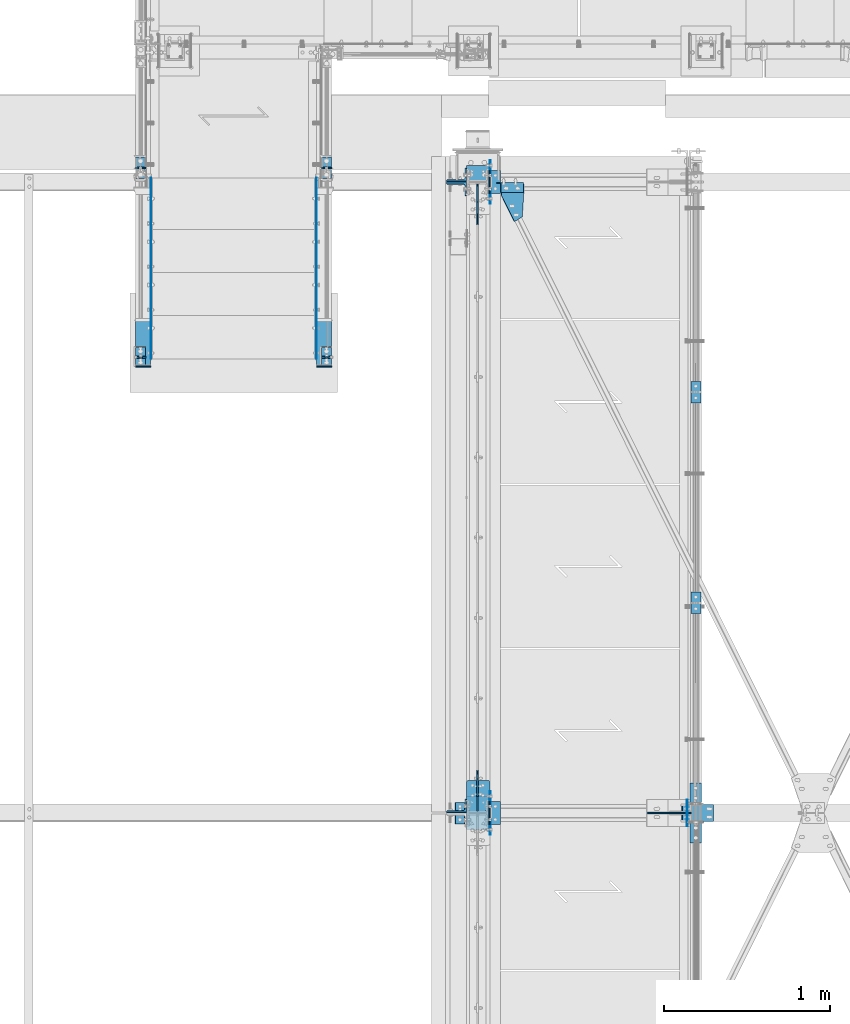
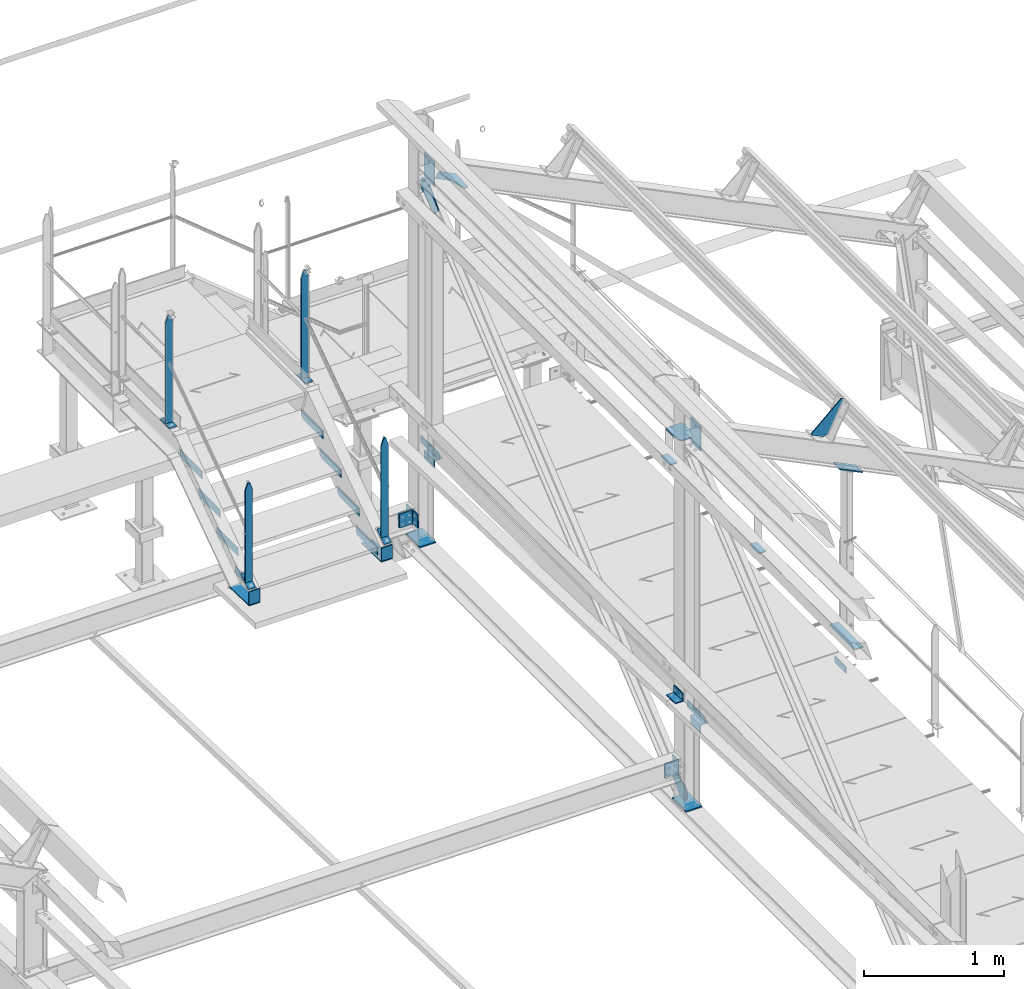
# One storey, part 110 of 496: 36 beams, 7 members, 25 elements without a shape of their own.
"""IFC2X3 building model written with IfcOpenShell, lengths in millimetres."""

from ifc_helpers import new_model, si_unit, frame, frame_2d, origin_with_axes, origin_2d_with_axis, place, context, subcontext, project, spatial, polyline, circle_curve, parameter, trimmed, segment, composite_curve, rectangle, l_section, outline, extrude, clip, halfspace, material, type_object, element, aggregate, save


model = new_model("IFC2X3")

# Units and contexts
model_context = context("Model", 3, precision=1e-05, world=origin_with_axes())
body_context = subcontext(model_context, "Body", "Model", "MODEL_VIEW")
ifc_project = project(units=[si_unit("LENGTHUNIT", "METRE", prefix="MILLI"), si_unit("AREAUNIT", "SQUARE_METRE"), si_unit("VOLUMEUNIT", "CUBIC_METRE"), si_unit("MASSUNIT", "GRAM", prefix="KILO"), si_unit("TIMEUNIT", "SECOND"), si_unit("PLANEANGLEUNIT", "RADIAN"), si_unit("SOLIDANGLEUNIT", "STERADIAN"), si_unit("THERMODYNAMICTEMPERATUREUNIT", "DEGREE_CELSIUS"), si_unit("LUMINOUSINTENSITYUNIT", "LUMEN")], contexts=[model_context])

# Site, building, storey
site_placement = place(None, origin_with_axes())
site = spatial("IfcSite", under=ifc_project, at=site_placement, CompositionType="ELEMENT")
building_placement = place(site_placement, origin_with_axes())
building = spatial("IfcBuilding", under=site, at=building_placement, Name="Undefined", CompositionType="ELEMENT")
storey_placement = place(building_placement, origin_with_axes())
storey = spatial("IfcBuildingStorey", under=building, at=storey_placement, Name="Undefined", CompositionType="ELEMENT", Elevation=0.0)

# Assembly, beams
assembly_1_placement = place(storey_placement, origin_with_axes())
assembly_1 = element("IfcElementAssembly", 1, at=assembly_1_placement, inside=storey, Name="MAIN COURANTE", AssemblyPlace="NOTDEFINED", PredefinedType="NOTDEFINED")
ifc_material = material(Name="Undefined/S235-E24")
beam_type_1 = type_object("IfcBeamType", PredefinedType="NOTDEFINED")
beam_1_placement = place(assembly_1_placement, frame((33369.9936634988, 15350.0038033311, 8915.0), z_axis=(1.0, 0.0, 0.0), x_axis=(0.0, -1.0, 0.0)))
beam_1 = element("IfcBeam", 2, at=beam_1_placement, type_object=beam_type_1, material=ifc_material, context=body_context, shape_type="SweptSolid", body=[
    extrude(rectangle(XDim=10.0, YDim=60.0, at=origin_2d_with_axis()), frame((130.0, 0.0, 0.0), z_axis=(-1.0, 0.0, 0.0), x_axis=(0.0, -1.0, 0.0)), (0.0, 0.0, 1.0), 130.0),
])
beam_2_placement = place(assembly_1_placement, frame((33369.9937887991, 15285.0038033311, 9857.59999847), z_axis=(0.999999999998558, -1.69800000185205e-06, 0.0), x_axis=(0.0, 0.0, -1.0)))
beam_2 = element("IfcBeam", 3, at=beam_2_placement, type_object=beam_type_1, material=ifc_material, Name="MONTANT", context=body_context, shape_type="Clipping", body=[
    clip(clip(extrude(rectangle(XDim=10.0, YDim=60.0, at=origin_2d_with_axis()), frame((937.599998469999, 0.0, 0.0), z_axis=(-1.0, 0.0, 0.0), x_axis=(0.0, -1.0, 0.0)), (0.0, 0.0, 1.0), 937.6), halfspace(frame((-119.999937359999, 4.99999999999818, -30.0), z_axis=(-0.316227766016843, 1.98085072621335e-06, 0.948683298048444), x_axis=(0.948683298050514, 0.0, 0.316227766016838)), False)), halfspace(frame((60.0, 5.0, -30.0), z_axis=(-0.316227469016822, -1.98084886580522e-06, -0.948683397048399), x_axis=(-0.948683298050514, 0.0, 0.316227766016838)), False)),
])

assembly_2_placement = place(storey_placement, origin_with_axes())
assembly_2 = element("IfcElementAssembly", 4, at=assembly_2_placement, inside=storey, Name="MAIN COURANTE", AssemblyPlace="NOTDEFINED", PredefinedType="NOTDEFINED")
beam_3_placement = place(assembly_2_placement, frame((32249.9863365012, 15350.0038033311, 8915.0), z_axis=(-1.0, 0.0, 0.0), x_axis=(0.0, -1.0, 0.0)))
beam_3 = element("IfcBeam", 5, at=beam_3_placement, type_object=beam_type_1, material=ifc_material, context=body_context, shape_type="SweptSolid", body=[
    extrude(rectangle(XDim=10.0, YDim=60.0, at=origin_2d_with_axis()), frame((130.0, 0.0, 0.0), z_axis=(-1.0, 0.0, 0.0), x_axis=(0.0, -1.0, 0.0)), (0.0, 0.0, 1.0), 130.0),
])
beam_4_placement = place(assembly_2_placement, frame((32249.9862112009, 15285.0038033311, 9857.59999847), z_axis=(-0.99999999999782, -2.08799998896818e-06, 0.0), x_axis=(0.0, 0.0, -1.0)))
beam_4 = element("IfcBeam", 6, at=beam_4_placement, type_object=beam_type_1, material=ifc_material, Name="MONTANT", context=body_context, shape_type="Clipping", body=[
    clip(clip(extrude(rectangle(XDim=10.0, YDim=60.0, at=origin_2d_with_axis()), frame((937.599998469999, 0.0, 0.0), z_axis=(-1.0, 0.0, 0.0), x_axis=(0.0, -1.0, 0.0)), (0.0, 0.0, 1.0), 937.6), halfspace(frame((-119.999937359999, -4.99999999999636, -30.0), z_axis=(-0.316227766016837, -1.98085072276202e-06, 0.948683298048446), x_axis=(-6.26399999950979e-06, 0.999999999980381, -3.63797880701241e-15)), False)), halfspace(frame((60.0, -5.0, -30.0), z_axis=(-0.316227469016822, 1.98084886235393e-06, -0.948683397048399), x_axis=(6.26399999950979e-06, 0.999999999980381, -3.63797880701241e-15)), False)),
])
beam_5_placement = place(assembly_2_placement, frame((32249.9862112009, 14144.9998536997, 9085.35366746007), z_axis=(-0.99999999999782, -2.08799998896818e-06, 0.0), x_axis=(0.0, 0.0, -1.0)))
beam_5 = element("IfcBeam", 7, at=beam_5_placement, type_object=beam_type_1, material=ifc_material, Name="MONTANT", context=body_context, shape_type="Clipping", body=[
    clip(clip(clip(clip(extrude(rectangle(XDim=10.0, YDim=60.0, at=origin_2d_with_axis()), frame((863.260305025577, 0.0, 0.0), z_axis=(-1.0, 0.0, 0.0), x_axis=(0.0, -1.0, 0.0)), (0.0, 0.0, 1.0), 870.25), halfspace(frame((-119.999937359999, -4.99999999999636, -30.0), z_axis=(-0.316227766016837, -1.98085072276202e-06, 0.948683298048446), x_axis=(-6.26399999950979e-06, 0.999999999980381, -3.63797880701241e-15)), False)), halfspace(frame((60.0, -5.0, -30.0), z_axis=(-0.316227469016822, 1.98084886235393e-06, -0.948683397048399), x_axis=(6.26399999950979e-06, 0.999999999980381, -3.63797880701241e-15)), False)), halfspace(frame((851.815615457686, -6.43113634479596, -0.000138728501042351), z_axis=(0.822192191679509, -0.569209978778308, -6.66011673277761e-07), x_axis=(0.569209978778308, 0.822192191677987, 1.71673729643302e-06)), False)), halfspace(frame((-7.87605918300687, -11.3765299322586, -0.000149054481880739), z_axis=(0.822192191679509, -0.569209978778308, -6.66011673277761e-07), x_axis=(0.569209978778308, 0.822192191677987, 1.71673729643302e-06)), True)),
])

# Beam
beam_6_placement = place(assembly_1_placement, frame((33369.9937887991, 14144.9998536997, 9085.35366746007), z_axis=(0.999999999998558, -1.69800000185205e-06, 0.0), x_axis=(0.0, 0.0, -1.0)))
beam_6 = element("IfcBeam", 8, at=beam_6_placement, type_object=beam_type_1, material=ifc_material, Name="MONTANT", context=body_context, shape_type="Clipping", body=[
    clip(clip(clip(clip(extrude(rectangle(XDim=10.0, YDim=60.0, at=origin_2d_with_axis()), frame((863.260305025577, 0.0, 0.0), z_axis=(-1.0, 0.0, 0.0), x_axis=(0.0, -1.0, 0.0)), (0.0, 0.0, 1.0), 870.25), halfspace(frame((-119.999937359999, 4.99999999999818, -30.0), z_axis=(-0.316227766016843, 1.98085072621335e-06, 0.948683298048444), x_axis=(0.948683298050514, 0.0, 0.316227766016838)), False)), halfspace(frame((60.0, 5.0, -30.0), z_axis=(-0.316227469016822, -1.98084886580522e-06, -0.948683397048399), x_axis=(-0.948683298050514, 0.0, 0.316227766016838)), False)), halfspace(frame((851.815615457686, 6.43113634479596, -0.000138728501042351), z_axis=(0.822192191679509, 0.569209978778308, -6.6601167379545e-07), x_axis=(0.0, -2.08799999927579e-06, -0.99999999999782)), False)), halfspace(frame((-7.87605918300687, 11.3765299322586, -0.000149054481880739), z_axis=(0.822192191679509, 0.569209978778308, -6.6601167379545e-07), x_axis=(0.0, -2.08799999927579e-06, -0.99999999999782)), True)),
])

# Assembly, beams
assembly_3_placement = place(storey_placement, origin_with_axes())
assembly_3 = element("IfcElementAssembly", 9, at=assembly_3_placement, inside=storey, Name="MAIN COURANTE", AssemblyPlace="NOTDEFINED", PredefinedType="NOTDEFINED")
beam_7_placement = place(assembly_3_placement, frame((35593.991720472, 12730.0034319682, 8245.00000008426), z_axis=(-1.0, 0.0, 0.0), x_axis=(0.0, -1.0, 0.0)))
beam_7 = element("IfcBeam", 10, at=beam_7_placement, type_object=beam_type_1, material=ifc_material, context=body_context, shape_type="SweptSolid", body=[
    extrude(rectangle(XDim=10.0, YDim=60.0, at=origin_2d_with_axis()), frame((130.0, 0.0, 0.0), z_axis=(-1.0, 0.0, 0.0), x_axis=(0.0, -1.0, 0.0)), (0.0, 0.0, 1.0), 130.0),
])
beam_8_placement = place(assembly_3_placement, frame((35593.9917215272, 14000.0034319682, 8244.99999921369), z_axis=(-1.0, 0.0, 0.0), x_axis=(0.0, -1.0, 0.0)))
beam_8 = element("IfcBeam", 11, at=beam_8_placement, type_object=beam_type_1, material=ifc_material, context=body_context, shape_type="SweptSolid", body=[
    extrude(rectangle(XDim=10.0, YDim=60.0, at=origin_2d_with_axis()), frame((130.0, 0.0, 0.0), z_axis=(-1.0, 0.0, 0.0), x_axis=(0.0, -1.0, 0.0)), (0.0, 0.0, 1.0), 130.0),
])
aggregate(assembly_3, [beam_7, beam_8])

# Member
member_type_1 = type_object("IfcMemberType", PredefinedType="NOTDEFINED")
member_1_placement = place(assembly_2_placement, frame((32249.9863365012, 14205.3993570111, 8264.81946439709), z_axis=(-1.0, 0.0, 0.0), x_axis=(8.10000000154612e-07, -0.822192191679509, -0.569209978778122)))
member_1 = element("IfcMember", 12, at=member_1_placement, type_object=member_type_1, material=ifc_material, context=body_context, shape_type="SweptSolid", body=[
    extrude(rectangle(XDim=10.0, YDim=60.0, at=origin_2d_with_axis()), frame((130.0, 0.0, 0.0), z_axis=(-1.0, 0.0, 0.0), x_axis=(0.0, -1.0, 0.0)), (0.0, 0.0, 1.0), 130.0),
])

aggregate(assembly_2, [member_1, beam_3, beam_4, beam_5])

member_2_placement = place(assembly_1_placement, frame((33369.9936634988, 14205.3993570111, 8264.81946439709), z_axis=(1.0, 0.0, 0.0), x_axis=(8.10000000154612e-07, -0.822192191679509, -0.569209978778122)))
member_2 = element("IfcMember", 13, at=member_2_placement, type_object=member_type_1, material=ifc_material, context=body_context, shape_type="SweptSolid", body=[
    extrude(rectangle(XDim=10.0, YDim=60.0, at=origin_2d_with_axis()), frame((130.0, 0.0, 0.0), z_axis=(-1.0, 0.0, 0.0), x_axis=(0.0, -1.0, 0.0)), (0.0, 0.0, 1.0), 130.0),
])

aggregate(assembly_1, [beam_1, beam_2, member_2, beam_6])

# Assembly, beams
assembly_4_placement = place(storey_placement, origin_with_axes())
assembly_4 = element("IfcElementAssembly", 14, at=assembly_4_placement, inside=storey, Name="MARCHE", AssemblyPlace="NOTDEFINED", PredefinedType="NOTDEFINED")
beam_type_2 = type_object("IfcBeamType", PredefinedType="NOTDEFINED")
beam_9_placement = place(assembly_4_placement, frame((32311.4947340707, 15224.9997910501, 8700.0), z_axis=(-1.0, 0.0, 0.0), x_axis=(0.0, 0.0, -1.0)))
beam_9 = element("IfcBeam", 15, at=beam_9_placement, type_object=beam_type_2, material=ifc_material, Name="PLAT MARCHE", context=body_context, shape_type="SweptSolid", body=[
    extrude(outline(polyline([(0.0, 0.0), (50.0, 0.0), (70.0, 30.0), (70.0, 310.0), (0.0, 310.0), (0.0, 0.0)])), frame((0.0, 0.0, -1.5), z_axis=(0.0, 0.0, 1.0), x_axis=(1.0, 0.0, 0.0)), (0.0, 0.0, 1.0), 3.0),
])
beam_10_placement = place(assembly_4_placement, frame((33308.4947340707, 15224.9997910501, 8700.0), z_axis=(-1.0, 0.0, 0.0), x_axis=(0.0, 0.0, -1.0)))
beam_10 = element("IfcBeam", 16, at=beam_10_placement, type_object=beam_type_2, material=ifc_material, Name="PLAT MARCHE", context=body_context, shape_type="SweptSolid", body=[
    extrude(outline(polyline([(0.0, 0.0), (50.0, 0.0), (70.0, 30.0), (70.0, 310.0), (0.0, 310.0), (0.0, 0.0)])), frame((0.0, 0.0, -1.5), z_axis=(0.0, 0.0, 1.0), x_axis=(1.0, 0.0, 0.0)), (0.0, 0.0, 1.0), 3.0),
])
aggregate(assembly_4, [beam_9, beam_10])

assembly_5_placement = place(storey_placement, origin_with_axes())
assembly_5 = element("IfcElementAssembly", 17, at=assembly_5_placement, inside=storey, Name="MARCHE", AssemblyPlace="NOTDEFINED", PredefinedType="NOTDEFINED")
beam_11_placement = place(assembly_5_placement, frame((32311.4947340707, 14964.9997910501, 8520.00000004865), z_axis=(-1.0, 0.0, 0.0), x_axis=(0.0, 0.0, -1.0)))
beam_11 = element("IfcBeam", 18, at=beam_11_placement, type_object=beam_type_2, material=ifc_material, Name="PLAT MARCHE", context=body_context, shape_type="SweptSolid", body=[
    extrude(outline(polyline([(0.0, 0.0), (50.0, 0.0), (70.0, 30.0), (70.0, 310.0), (0.0, 310.0), (0.0, 0.0)])), frame((0.0, 0.0, -1.5), z_axis=(0.0, 0.0, 1.0), x_axis=(1.0, 0.0, 0.0)), (0.0, 0.0, 1.0), 3.0),
])
beam_12_placement = place(assembly_5_placement, frame((33308.4947340707, 14964.9997910501, 8520.00000004865), z_axis=(-1.0, 0.0, 0.0), x_axis=(0.0, 0.0, -1.0)))
beam_12 = element("IfcBeam", 19, at=beam_12_placement, type_object=beam_type_2, material=ifc_material, Name="PLAT MARCHE", context=body_context, shape_type="SweptSolid", body=[
    extrude(outline(polyline([(0.0, 0.0), (50.0, 0.0), (70.0, 30.0), (70.0, 310.0), (0.0, 310.0), (0.0, 0.0)])), frame((0.0, 0.0, -1.5), z_axis=(0.0, 0.0, 1.0), x_axis=(1.0, 0.0, 0.0)), (0.0, 0.0, 1.0), 3.0),
])
aggregate(assembly_5, [beam_11, beam_12])

assembly_6_placement = place(storey_placement, origin_with_axes())
assembly_6 = element("IfcElementAssembly", 20, at=assembly_6_placement, inside=storey, Name="MARCHE", AssemblyPlace="NOTDEFINED", PredefinedType="NOTDEFINED")
beam_13_placement = place(assembly_6_placement, frame((32311.4947340707, 14704.9997910501, 8340.00000007297), z_axis=(-1.0, 0.0, 0.0), x_axis=(0.0, 0.0, -1.0)))
beam_13 = element("IfcBeam", 21, at=beam_13_placement, type_object=beam_type_2, material=ifc_material, Name="PLAT MARCHE", context=body_context, shape_type="SweptSolid", body=[
    extrude(outline(polyline([(0.0, 0.0), (50.0, 0.0), (70.0, 30.0), (70.0, 310.0), (0.0, 310.0), (0.0, 0.0)])), frame((0.0, 0.0, -1.5), z_axis=(0.0, 0.0, 1.0), x_axis=(1.0, 0.0, 0.0)), (0.0, 0.0, 1.0), 3.0),
])
beam_14_placement = place(assembly_6_placement, frame((33308.4947340707, 14704.9997910501, 8340.00000007297), z_axis=(-1.0, 0.0, 0.0), x_axis=(0.0, 0.0, -1.0)))
beam_14 = element("IfcBeam", 22, at=beam_14_placement, type_object=beam_type_2, material=ifc_material, Name="PLAT MARCHE", context=body_context, shape_type="SweptSolid", body=[
    extrude(outline(polyline([(0.0, 0.0), (50.0, 0.0), (70.0, 30.0), (70.0, 310.0), (0.0, 310.0), (0.0, 0.0)])), frame((0.0, 0.0, -1.5), z_axis=(0.0, 0.0, 1.0), x_axis=(1.0, 0.0, 0.0)), (0.0, 0.0, 1.0), 3.0),
])
aggregate(assembly_6, [beam_13, beam_14])

assembly_7_placement = place(storey_placement, origin_with_axes())
assembly_7 = element("IfcElementAssembly", 23, at=assembly_7_placement, inside=storey, Name="MARCHE", AssemblyPlace="NOTDEFINED", PredefinedType="NOTDEFINED")
beam_15_placement = place(assembly_7_placement, frame((32311.4947340707, 14444.9997910501, 8160.0000000973), z_axis=(-1.0, 0.0, 0.0), x_axis=(0.0, 0.0, -1.0)))
beam_15 = element("IfcBeam", 24, at=beam_15_placement, type_object=beam_type_2, material=ifc_material, Name="PLAT MARCHE", context=body_context, shape_type="SweptSolid", body=[
    extrude(outline(polyline([(0.0, 0.0), (50.0, 0.0), (70.0, 30.0), (70.0, 310.0), (0.0, 310.0), (0.0, 0.0)])), frame((0.0, 0.0, -1.5), z_axis=(0.0, 0.0, 1.0), x_axis=(1.0, 0.0, 0.0)), (0.0, 0.0, 1.0), 3.0),
])
beam_16_placement = place(assembly_7_placement, frame((33308.4947340707, 14444.9997910501, 8160.0000000973), z_axis=(-1.0, 0.0, 0.0), x_axis=(0.0, 0.0, -1.0)))
beam_16 = element("IfcBeam", 25, at=beam_16_placement, type_object=beam_type_2, material=ifc_material, Name="PLAT MARCHE", context=body_context, shape_type="SweptSolid", body=[
    extrude(outline(polyline([(0.0, 0.0), (50.0, 0.0), (70.0, 30.0), (70.0, 310.0), (0.0, 310.0), (0.0, 0.0)])), frame((0.0, 0.0, -1.5), z_axis=(0.0, 0.0, 1.0), x_axis=(1.0, 0.0, 0.0)), (0.0, 0.0, 1.0), 3.0),
])
aggregate(assembly_7, [beam_15, beam_16])

assembly_8_placement = place(storey_placement, origin_with_axes())
assembly_8 = element("IfcElementAssembly", 26, at=assembly_8_placement, inside=storey, AssemblyPlace="NOTDEFINED", PredefinedType="NOTDEFINED")
beam_type_3 = type_object("IfcBeamType", PredefinedType="NOTDEFINED")
beam_17_placement = place(assembly_8_placement, frame((33354.9938754006, 14370.1040990241, 8052.62545207049), z_axis=(1.0, 0.0, 0.0), x_axis=(0.0, -0.999506556345276, 0.031410887010852)))
beam_17 = element("IfcBeam", 27, at=beam_17_placement, type_object=beam_type_3, material=ifc_material, Name="PLAT", context=body_context, shape_type="SweptSolid", body=[
    extrude(rectangle(XDim=8.0, YDim=90.0, at=origin_2d_with_axis()), frame((285.370765885938, 0.0, 0.0), z_axis=(-1.0, 0.0, 0.0), x_axis=(0.0, -1.0, 0.0)), (0.0, 0.0, 1.0), 285.37),
])
beam_18_placement = place(assembly_8_placement, frame((33354.9938754006, 14088.9997910799, 8180.92307703739), z_axis=(1.0, 0.0, 0.0), x_axis=(0.0, 0.0, -1.0)))
beam_18 = element("IfcBeam", 28, at=beam_18_placement, type_object=beam_type_3, material=ifc_material, Name="PLAT", context=body_context, shape_type="SweptSolid", body=[
    extrude(rectangle(XDim=8.0, YDim=90.0, at=origin_2d_with_axis()), frame((114.997260996663, 0.0, 0.0), z_axis=(-1.0, 0.0, 0.0), x_axis=(0.0, -1.0, 0.0)), (0.0, 0.0, 1.0), 115.0),
])
aggregate(assembly_8, [beam_17, beam_18])

assembly_9_placement = place(storey_placement, origin_with_axes())
assembly_9 = element("IfcElementAssembly", 29, at=assembly_9_placement, inside=storey, AssemblyPlace="NOTDEFINED", PredefinedType="NOTDEFINED")
beam_19_placement = place(assembly_9_placement, frame((32265.0061245995, 14370.1040990241, 8052.62545207049), z_axis=(-1.0, 0.0, 0.0), x_axis=(0.0, -0.999506556345276, 0.031410887010852)))
beam_19 = element("IfcBeam", 30, at=beam_19_placement, type_object=beam_type_3, material=ifc_material, Name="PLAT", context=body_context, shape_type="SweptSolid", body=[
    extrude(rectangle(XDim=8.0, YDim=90.0, at=origin_2d_with_axis()), frame((285.370765885938, 0.0, 0.0), z_axis=(-1.0, 0.0, 0.0), x_axis=(0.0, -1.0, 0.0)), (0.0, 0.0, 1.0), 285.37),
])
beam_20_placement = place(assembly_9_placement, frame((32265.0061245995, 14088.9997910799, 8180.92307703739), z_axis=(-1.0, 0.0, 0.0), x_axis=(0.0, 0.0, -1.0)))
beam_20 = element("IfcBeam", 31, at=beam_20_placement, type_object=beam_type_3, material=ifc_material, Name="PLAT", context=body_context, shape_type="SweptSolid", body=[
    extrude(rectangle(XDim=8.0, YDim=90.0, at=origin_2d_with_axis()), frame((114.997260996663, 0.0, 0.0), z_axis=(-1.0, 0.0, 0.0), x_axis=(0.0, -1.0, 0.0)), (0.0, 0.0, 1.0), 115.0),
])
aggregate(assembly_9, [beam_19, beam_20])

# Assembly, beam
assembly_10_placement = place(storey_placement, origin_with_axes())
assembly_10 = element("IfcElementAssembly", 32, at=assembly_10_placement, inside=storey, AssemblyPlace="NOTDEFINED", PredefinedType="NOTDEFINED")
beam_type_4 = type_object("IfcBeamType", PredefinedType="NOTDEFINED")
beam_21_placement = place(assembly_10_placement, frame((34381.5000576363, 15130.0, 7915.0), z_axis=(1.0, 0.0, 0.0), x_axis=(0.0, 1.0, 0.0)))
beam_21 = element("IfcBeam", 33, at=beam_21_placement, type_object=beam_type_4, material=ifc_material, context=body_context, shape_type="SweptSolid", body=[
    extrude(l_section(Depth=70.0, Width=70.0, Thickness=7.0, FilletRadius=9.0, EdgeRadius=4.5, at=origin_2d_with_axis()), frame((140.0, 0.0, 0.0), z_axis=(-1.0, 0.0, 0.0), x_axis=(0.0, -1.0, 0.0)), (0.0, 0.0, 1.0), 140.0),
])
aggregate(assembly_10, [beam_21])

assembly_11_placement = place(storey_placement, origin_with_axes())
assembly_11 = element("IfcElementAssembly", 34, at=assembly_11_placement, inside=storey, AssemblyPlace="NOTDEFINED", PredefinedType="NOTDEFINED")
beam_22_placement = place(assembly_11_placement, frame((34381.5000576363, 11330.0, 7915.0), z_axis=(1.0, 0.0, 0.0), x_axis=(0.0, 1.0, 0.0)))
beam_22 = element("IfcBeam", 35, at=beam_22_placement, type_object=beam_type_4, material=ifc_material, context=body_context, shape_type="SweptSolid", body=[
    extrude(l_section(Depth=70.0, Width=70.0, Thickness=7.0, FilletRadius=9.0, EdgeRadius=4.5, at=origin_2d_with_axis()), frame((140.0, 0.0, 0.0), z_axis=(-1.0, 0.0, 0.0), x_axis=(0.0, -1.0, 0.0)), (0.0, 0.0, 1.0), 140.0),
])
aggregate(assembly_11, [beam_22])

assembly_12_placement = place(storey_placement, origin_with_axes())
assembly_12 = element("IfcElementAssembly", 36, at=assembly_12_placement, inside=storey, AssemblyPlace="NOTDEFINED", PredefinedType="NOTDEFINED")
beam_23_placement = place(assembly_12_placement, frame((34178.5001163161, 11464.8129140242, 8229.98135168843), z_axis=(0.0, 0.0314135610096692, 0.999506472307554), x_axis=(0.0, -0.999506472307554, 0.031413561009669)))
beam_23 = element("IfcBeam", 37, at=beam_23_placement, type_object=beam_type_4, material=ifc_material, context=body_context, shape_type="SweptSolid", body=[
    extrude(l_section(Depth=70.0, Width=70.0, Thickness=7.0, FilletRadius=9.0, EdgeRadius=4.5, at=origin_2d_with_axis()), frame((130.004127993981, 0.0, 9.02084851220212e-16), z_axis=(-1.0, 0.0, 0.0), x_axis=(0.0, -1.0, 0.0)), (0.0, 0.0, 1.0), 130.0),
])
aggregate(assembly_12, [beam_23])

# Assembly, member
assembly_13_placement = place(storey_placement, origin_with_axes())
assembly_13 = element("IfcElementAssembly", 38, at=assembly_13_placement, inside=storey, AssemblyPlace="NOTDEFINED", PredefinedType="NOTDEFINED")
member_type_2 = type_object("IfcMemberType", PredefinedType="NOTDEFINED")
member_3_placement = place(assembly_13_placement, frame((34407.7039823223, 15167.0004268974, 10376.0796849562), z_axis=(0.0, -1.0, 0.0), x_axis=(0.897398510539058, 0.0, -0.441220934773362)))
member_3 = element("IfcMember", 39, at=member_3_placement, type_object=member_type_2, material=ifc_material, context=body_context, shape_type="SweptSolid", body=[
    extrude(l_section(Depth=60.0, Width=60.0, Thickness=6.0, FilletRadius=8.0, EdgeRadius=4.0, at=origin_2d_with_axis()), frame((149.999995982835, 4.54747350886464e-12, 3.63797880709171e-12), z_axis=(-1.0, 0.0, 0.0), x_axis=(0.0, -1.0, 0.0)), (0.0, 0.0, 1.0), 150.0),
])
aggregate(assembly_13, [member_3])

# Assembly, beam
assembly_14_placement = place(storey_placement, origin_with_axes())
assembly_14 = element("IfcElementAssembly", 40, at=assembly_14_placement, inside=storey, Name="SHED", AssemblyPlace="NOTDEFINED", PredefinedType="NOTDEFINED")
beam_type_5 = type_object("IfcBeamType", PredefinedType="NOTDEFINED")
beam_24_placement = place(assembly_14_placement, frame((35310.1044072469, 11400.0, 10117.3786897729), z_axis=(0.0, -1.0, 0.0), x_axis=(-0.441220935974661, 0.0, -0.89739850994842)))
beam_24 = element("IfcBeam", 41, at=beam_24_placement, type_object=beam_type_5, material=ifc_material, context=body_context, shape_type="SweptSolid", body=[
    extrude(outline(polyline([(0.0, 0.0), (20.0, 0.0), (20.0000000002019, 109.999999999982), (-9.99999999974731, 139.99998998623), (-300.0000000002, 139.999893186625), (-300.000000000226, 119.999893186643), (0.0, 0.0)])), frame((0.0, 0.0, -4.0), z_axis=(0.0, 0.0, 1.0), x_axis=(1.0, 0.0, 0.0)), (0.0, 0.0, 1.0), 8.0),
])
aggregate(assembly_14, [beam_24])

assembly_15_placement = place(storey_placement, origin_with_axes())
assembly_15 = element("IfcElementAssembly", 42, at=assembly_15_placement, inside=storey, Name="MONTANT", AssemblyPlace="NOTDEFINED", PredefinedType="NOTDEFINED")
beam_type_6 = type_object("IfcBeamType", PredefinedType="NOTDEFINED")
beam_25_placement = place(assembly_15_placement, frame((34280.0, 15300.0, 7255.0), z_axis=(1.0, 0.0, 0.0), x_axis=(0.0, -1.0, 0.0)))
beam_25 = element("IfcBeam", 43, at=beam_25_placement, type_object=beam_type_6, material=ifc_material, context=body_context, shape_type="SweptSolid", body=[
    extrude(rectangle(XDim=10.0, YDim=133.0, at=origin_2d_with_axis()), frame((200.0, 0.0, 0.0), z_axis=(-1.0, 0.0, 0.0), x_axis=(0.0, -1.0, 0.0)), (0.0, 0.0, 1.0), 200.0),
])

assembly_16_placement = place(storey_placement, origin_with_axes())
assembly_16 = element("IfcElementAssembly", 44, at=assembly_16_placement, inside=storey, Name="MONTANT", AssemblyPlace="NOTDEFINED", PredefinedType="NOTDEFINED")
beam_26_placement = place(assembly_16_placement, frame((34280.0, 11500.0, 7255.0), z_axis=(1.0, 0.0, 0.0), x_axis=(0.0, -1.0, 0.0)))
beam_26 = element("IfcBeam", 45, at=beam_26_placement, type_object=beam_type_6, material=ifc_material, context=body_context, shape_type="SweptSolid", body=[
    extrude(rectangle(XDim=10.0, YDim=133.0, at=origin_2d_with_axis()), frame((200.0, 0.0, 0.0), z_axis=(-1.0, 0.0, 0.0), x_axis=(0.0, -1.0, 0.0)), (0.0, 0.0, 1.0), 200.0),
])

# Assembly, member
assembly_17_placement = place(storey_placement, origin_with_axes())
assembly_17 = element("IfcElementAssembly", 46, at=assembly_17_placement, inside=storey, AssemblyPlace="NOTDEFINED", PredefinedType="NOTDEFINED")
member_type_3 = type_object("IfcMemberType", PredefinedType="NOTDEFINED")
member_4_placement = place(assembly_17_placement, frame((35511.0197434437, 11400.0000000133, 9756.72720417295), z_axis=(0.0, -1.0, 0.0), x_axis=(0.897398510539058, 0.0, -0.441220934773362)))
member_4 = element("IfcMember", 47, at=member_4_placement, type_object=member_type_3, material=ifc_material, context=body_context, shape_type="SweptSolid", body=[
    extrude(rectangle(XDim=10.0, YDim=100.0, at=origin_2d_with_axis()), frame((210.000000000491, 0.0, 1.81898940354586e-12), z_axis=(-1.0, 0.0, 0.0), x_axis=(0.0, -1.0, 0.0)), (0.0, 0.0, 1.0), 210.0),
])

# Assembly, beam
assembly_18_placement = place(storey_placement, origin_with_axes())
assembly_18 = element("IfcElementAssembly", 48, at=assembly_18_placement, inside=storey, AssemblyPlace="NOTDEFINED", PredefinedType="NOTDEFINED")
beam_type_7 = type_object("IfcBeamType", PredefinedType="NOTDEFINED")
beam_27_placement = place(assembly_18_placement, frame((35542.9917140619, 11320.0, 7985.0), z_axis=(-1.0, 0.0, 0.0), x_axis=(0.0, 0.0, 1.0)))
beam_27 = element("IfcBeam", 49, at=beam_27_placement, type_object=beam_type_7, material=ifc_material, context=body_context, shape_type="SweptSolid", body=[
    extrude(outline(polyline([(0.0, 0.0), (60.0, 0.0), (60.0, 159.999984741211), (0.0, 159.999984741211), (0.0, 0.0)])), frame((0.0, 0.0, -3.0), z_axis=(0.0, 0.0, 1.0), x_axis=(1.0, 0.0, 0.0)), (0.0, 0.0, 1.0), 6.0),
])

assembly_19_placement = place(storey_placement, origin_with_axes())
assembly_19 = element("IfcElementAssembly", 50, at=assembly_19_placement, inside=storey, AssemblyPlace="NOTDEFINED", PredefinedType="NOTDEFINED")
beam_28_placement = place(assembly_19_placement, frame((34354.991943003, 15070.0, 7985.0), z_axis=(-1.0, 0.0, 0.0), x_axis=(0.0, 0.0, 1.0)))
beam_28 = element("IfcBeam", 51, at=beam_28_placement, type_object=beam_type_7, material=ifc_material, context=body_context, shape_type="SweptSolid", body=[
    extrude(outline(polyline([(0.0, 0.0), (60.0, 0.0), (60.0, 260.0), (0.0, 260.0), (0.0, 0.0)])), frame((0.0, 0.0, -3.0), z_axis=(0.0, 0.0, 1.0), x_axis=(1.0, 0.0, 0.0)), (0.0, 0.0, 1.0), 6.0),
])
aggregate(assembly_19, [beam_28])

# Beam
beam_29_placement = place(assembly_18_placement, frame((34354.991943003, 11270.0, 7985.0), z_axis=(-1.0, 0.0, 0.0), x_axis=(0.0, 0.0, 1.0)))
beam_29 = element("IfcBeam", 52, at=beam_29_placement, type_object=beam_type_7, material=ifc_material, context=body_context, shape_type="SweptSolid", body=[
    extrude(outline(polyline([(0.0, 0.0), (60.0, 0.0), (60.0, 260.0), (0.0, 260.0), (0.0, 0.0)])), frame((0.0, 0.0, -3.0), z_axis=(0.0, 0.0, 1.0), x_axis=(1.0, 0.0, 0.0)), (0.0, 0.0, 1.0), 6.0),
])

aggregate(assembly_18, [beam_27, beam_29])

beam_type_8 = type_object("IfcBeamType", PredefinedType="NOTDEFINED")
beam_30_placement = place(assembly_17_placement, frame((35593.9917140619, 11580.0001061627, 8245.00000367738), z_axis=(1.0, 0.0, 0.0), x_axis=(0.0, -1.0, 0.0)))
beam_30 = element("IfcBeam", 53, at=beam_30_placement, type_object=beam_type_8, material=ifc_material, context=body_context, shape_type="SweptSolid", body=[
    extrude(rectangle(XDim=10.0, YDim=70.0, at=origin_2d_with_axis()), frame((360.000000000004, 0.0, 0.0), z_axis=(-1.0, 0.0, 0.0), x_axis=(0.0, -1.0, 0.0)), (0.0, 0.0, 1.0), 360.0),
])

aggregate(assembly_17, [member_4, beam_30])

# Assembly, beam
assembly_20_placement = place(storey_placement, origin_with_axes())
assembly_20 = element("IfcElementAssembly", 54, at=assembly_20_placement, inside=storey, Name="TRAVERSE SHED", AssemblyPlace="NOTDEFINED", PredefinedType="NOTDEFINED")
beam_type_9 = type_object("IfcBeamType", PredefinedType="NOTDEFINED")
beam_31_placement = place(assembly_20_placement, frame((34351.5, 15200.0, 10548.0682550821), z_axis=(0.0, -1.0, 0.0), x_axis=(0.0, 0.0, -1.0)))
beam_31 = element("IfcBeam", 55, at=beam_31_placement, type_object=beam_type_9, material=ifc_material, context=body_context, shape_type="SweptSolid", body=[
    extrude(rectangle(XDim=10.0, YDim=140.0, at=origin_2d_with_axis()), frame((213.394604237721, 0.0, 0.0), z_axis=(-1.0, 0.0, 0.0), x_axis=(0.0, -1.0, 0.0)), (0.0, 0.0, 1.0), 213.39),
])
aggregate(assembly_20, [beam_31])

assembly_21_placement = place(storey_placement, origin_with_axes())
assembly_21 = element("IfcElementAssembly", 56, at=assembly_21_placement, inside=storey, Name="TRAVERSE SHED", AssemblyPlace="NOTDEFINED", PredefinedType="NOTDEFINED")
beam_32_placement = place(assembly_21_placement, frame((34351.5, 11400.0, 10548.0682550821), z_axis=(0.0, -1.0, 0.0), x_axis=(0.0, 0.0, -1.0)))
beam_32 = element("IfcBeam", 57, at=beam_32_placement, type_object=beam_type_9, material=ifc_material, context=body_context, shape_type="SweptSolid", body=[
    extrude(rectangle(XDim=10.0, YDim=140.0, at=origin_2d_with_axis()), frame((213.394604237721, 0.0, 0.0), z_axis=(-1.0, 0.0, 0.0), x_axis=(0.0, -1.0, 0.0)), (0.0, 0.0, 1.0), 213.39),
])
aggregate(assembly_21, [beam_32])

assembly_22_placement = place(storey_placement, origin_with_axes())
assembly_22 = element("IfcElementAssembly", 58, at=assembly_22_placement, inside=storey, AssemblyPlace="NOTDEFINED", PredefinedType="NOTDEFINED")
beam_type_10 = type_object("IfcBeamType", PredefinedType="NOTDEFINED")
beam_33_placement = place(assembly_22_placement, frame((34548.1682092251, 14990.7417182445, 10343.7911110844), z_axis=(-0.441220935974661, 0.0, -0.89739850994842), x_axis=(-0.784869552886434, -0.484835707091843, 0.385893925944167)))
beam_33 = element("IfcBeam", 59, at=beam_33_placement, type_object=beam_type_10, material=ifc_material, context=body_context, shape_type="SweptSolid", body=[
    extrude(outline(polyline([(0.0, 0.0), (60.0, 0.0), (60.000000001357, 181.13842773447), (27.5527534497232, 239.6707305907), (-103.638031004382, 166.945343016534), (-79.3962478622052, 123.215103148526), (0.0, 0.0)])), frame((0.0, 0.0, -3.0), z_axis=(0.0, 0.0, 1.0), x_axis=(1.0, 0.0, 0.0)), (0.0, 0.0, 1.0), 6.0),
])
aggregate(assembly_22, [beam_33])

# Assembly, member
assembly_23_placement = place(storey_placement, origin_with_axes())
assembly_23 = element("IfcElementAssembly", 60, at=assembly_23_placement, inside=storey, AssemblyPlace="NOTDEFINED", PredefinedType="NOTDEFINED")
member_type_4 = type_object("IfcMemberType", PredefinedType="NOTDEFINED")
member_5_placement = place(assembly_23_placement, frame((34153.5000000005, 15244.8642482596, 7530.88751296081), z_axis=(-1.0, 0.0, 0.0), x_axis=(0.0, -0.031410887010906, -0.999506556345274)))
member_5 = element("IfcMember", 61, at=member_5_placement, type_object=member_type_4, material=ifc_material, context=body_context, shape_type="SweptSolid", body=[
    extrude(l_section(Depth=120.0, Width=80.0, Thickness=10.0, FilletRadius=11.0, EdgeRadius=5.5, at=origin_2d_with_axis()), frame((120.0, 0.0, 0.0), z_axis=(-1.0, 0.0, 0.0), x_axis=(0.0, -1.0, 0.0)), (0.0, 0.0, 1.0), 120.0),
])
aggregate(assembly_23, [member_5])

assembly_24_placement = place(storey_placement, origin_with_axes())
assembly_24 = element("IfcElementAssembly", 62, at=assembly_24_placement, inside=storey, AssemblyPlace="NOTDEFINED", PredefinedType="NOTDEFINED")
member_6_placement = place(assembly_24_placement, frame((34153.5000000006, 15155.1364772825, 7413.64811928459), z_axis=(-1.0, 0.0, 0.0), x_axis=(0.0, 0.031410887010906, 0.999506556345274)))
member_6 = element("IfcMember", 63, at=member_6_placement, type_object=member_type_4, material=ifc_material, context=body_context, shape_type="SweptSolid", body=[
    extrude(l_section(Depth=120.0, Width=80.0, Thickness=10.0, FilletRadius=11.0, EdgeRadius=5.5, at=origin_2d_with_axis()), frame((120.0, 0.0, 0.0), z_axis=(-1.0, 0.0, 0.0), x_axis=(0.0, -1.0, 0.0)), (0.0, 0.0, 1.0), 120.0),
])
aggregate(assembly_24, [member_6])

assembly_25_placement = place(storey_placement, origin_with_axes())
assembly_25 = element("IfcElementAssembly", 64, at=assembly_25_placement, inside=storey, AssemblyPlace="NOTDEFINED", PredefinedType="NOTDEFINED")
member_7_placement = place(assembly_25_placement, frame((34153.5000000005, 11444.8643025166, 7650.30906880405), z_axis=(-1.0, 0.0, 0.0), x_axis=(0.0, -0.031410887010906, -0.999506556345274)))
member_7 = element("IfcMember", 65, at=member_7_placement, type_object=member_type_4, material=ifc_material, context=body_context, shape_type="SweptSolid", body=[
    extrude(l_section(Depth=120.0, Width=80.0, Thickness=10.0, FilletRadius=11.0, EdgeRadius=5.5, at=origin_2d_with_axis()), frame((120.0, 0.0, 0.0), z_axis=(-1.0, 0.0, 0.0), x_axis=(0.0, -1.0, 0.0)), (0.0, 0.0, 1.0), 120.0),
])
aggregate(assembly_25, [member_7])

# Beam
beam_type_11 = type_object("IfcBeamType", PredefinedType="NOTDEFINED")
beam_34_placement = place(assembly_15_placement, frame((34280.0, 15079.9969221117, 10413.0), z_axis=(-1.0, 0.0, 0.0), x_axis=(0.0, 1.0, 0.0)))
beam_34 = element("IfcBeam", 66, at=beam_34_placement, type_object=beam_type_11, material=ifc_material, context=body_context, shape_type="SweptSolid", body=[
    extrude(outline(polyline([(0.0, 0.0), (97.25, 0.0), (117.25, 20.0), (117.25, 100.0), (-84.6368789672852, 212.985397338867), (-135.912002563477, 151.578063964844), (0.0, 0.0)])), frame((0.0, 0.0, -4.0), z_axis=(0.0, 0.0, 1.0), x_axis=(1.0, 0.0, 0.0)), (0.0, 0.0, 1.0), 8.0),
])

aggregate(assembly_15, [beam_34, beam_25])

beam_type_12 = type_object("IfcBeamType", PredefinedType="NOTDEFINED")
beam_35_placement = place(assembly_16_placement, frame((34280.0, 11500.0, 7260.0), z_axis=(-1.0, 0.0, 0.0), x_axis=(0.0, -1.0, 0.0)))
beam_35 = element("IfcBeam", 67, at=beam_35_placement, type_object=beam_type_12, material=ifc_material, context=body_context, shape_type="SweptSolid", body=[
    extrude(outline(polyline([(0.0, 0.0), (77.25, 0.0), (97.25, 20.0), (97.25, 100.0), (-104.639953613281, 212.985397338867), (-155.915084838867, 151.578063964844), (0.0, 0.0)])), frame((0.0, 0.0, -4.0), z_axis=(0.0, 0.0, 1.0), x_axis=(1.0, 0.0, 0.0)), (0.0, 0.0, 1.0), 8.0),
])

beam_type_13 = type_object("IfcBeamType", PredefinedType="NOTDEFINED")
beam_36_placement = place(assembly_16_placement, frame((34213.5, 11595.0, 10418.0), z_axis=(0.0, 0.0, 1.0), x_axis=(0.0, -1.0, 0.0)))
beam_36 = element("IfcBeam", 68, at=beam_36_placement, type_object=beam_type_13, material=ifc_material, Name="PLAT", context=body_context, shape_type="SweptSolid", body=[
    extrude(outline(composite_curve([segment(trimmed(circle_curve(frame_2d((10.0, 10.0), x_axis=(-1.0, 0.0)), 10.0), [parameter(0.0)], [parameter(1.5707963267949)], True, "PARAMETER"), True, "CONTINUOUS"), segment(polyline([(9.99999999997453, 6.91215973347425e-11), (124.5, 0.0), (124.5, 9.0), (172.25, 9.0), (192.25, 29.0), (192.25, 104.0), (172.25, 124.0), (124.0, 124.0), (124.0, 140.0), (10.0, 140.0)]), True, "CONTINUOUS"), segment(trimmed(circle_curve(frame_2d((10.0, 130.0), x_axis=(0.0, 1.0)), 10.0), [parameter(0.0)], [parameter(1.5707963267949)], True, "PARAMETER"), True, "CONTINUOUS"), segment(polyline([(0.0, 130.0), (-1.81898940354586e-10, 10.0000000000073)]), True, "CONTINUOUS")], self_intersect=True)), frame((0.0, 0.0, -5.0), z_axis=(0.0, 0.0, 1.0), x_axis=(1.0, 0.0, 0.0)), (0.0, 0.0, 1.0), 10.0),
])

aggregate(assembly_16, [beam_35, beam_26, beam_36])

save(model, "model.ifc")
